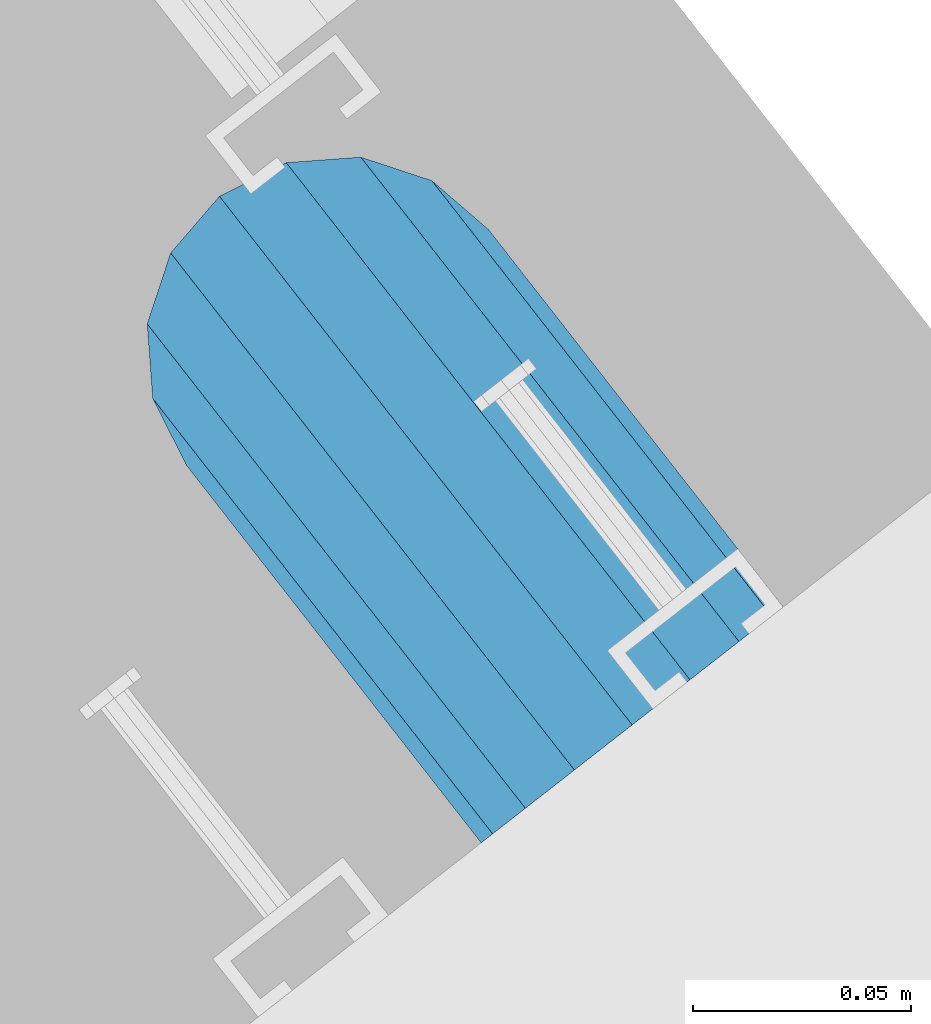
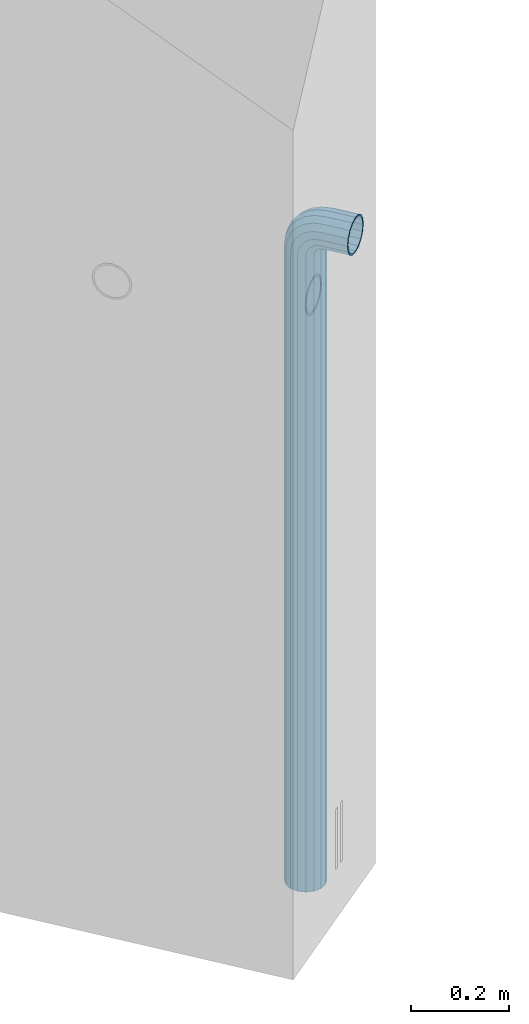
# One storey, part 6 of 42: 1 beam, 2 elements without a shape of their own.
"""IFC2X3 building model written with IfcOpenShell, lengths in millimetres."""

from ifc_helpers import new_model, si_unit, frame, origin_with_axes, place, context, subcontext, project, spatial, faceted_brep, material, type_object, element, aggregate, save


model = new_model("IFC2X3")

# Units and contexts
model_context = context("Model", 3, precision=1e-05, world=origin_with_axes())
body_context = subcontext(model_context, "Body", "Model", "MODEL_VIEW")
ifc_project = project(units=[si_unit("LENGTHUNIT", "METRE", prefix="MILLI"), si_unit("AREAUNIT", "SQUARE_METRE"), si_unit("VOLUMEUNIT", "CUBIC_METRE"), si_unit("MASSUNIT", "GRAM", prefix="KILO"), si_unit("TIMEUNIT", "SECOND"), si_unit("PLANEANGLEUNIT", "RADIAN"), si_unit("SOLIDANGLEUNIT", "STERADIAN"), si_unit("THERMODYNAMICTEMPERATUREUNIT", "DEGREE_CELSIUS"), si_unit("LUMINOUSINTENSITYUNIT", "LUMEN")], contexts=[model_context])

# Site, building, storey
site_placement = place(None, frame((171687.4, 84828.52, 14700.0), z_axis=(0.0, 0.0, 1.0), x_axis=(1.0, 0.0, 0.0)))
site = spatial("IfcSite", under=ifc_project, at=site_placement, CompositionType="ELEMENT")
building_placement = place(site_placement, origin_with_axes())
building = spatial("IfcBuilding", under=site, at=building_placement, Name="Undefined", CompositionType="ELEMENT")
storey_placement = place(building_placement, origin_with_axes())
storey = spatial("IfcBuildingStorey", under=building, at=storey_placement, Name="Undefined", CompositionType="ELEMENT", Elevation=0.0)

# Assemblies, beam
assembly_1_placement = place(storey_placement, origin_with_axes())
assembly_1 = element("IfcElementAssembly", 1, at=assembly_1_placement, inside=storey, AssemblyPlace="NOTDEFINED", PredefinedType="REINFORCEMENT_UNIT")
assembly_2_placement = place(assembly_1_placement, origin_with_axes())
assembly_2 = element("IfcElementAssembly", 2, at=assembly_2_placement, AssemblyPlace="NOTDEFINED", PredefinedType="RIGID_FRAME")
aggregate(assembly_1, [assembly_2])
ifc_material = material(Name="STEEL/NEG_BETON")
beam_type = type_object("IfcBeamType", PredefinedType="NOTDEFINED")
beam_placement = place(assembly_2_placement, frame((18365.8936635989, 265191.472412349, -1290.0), z_axis=(0.615386370178831, -0.788225611990706, 0.0), x_axis=(0.0, 0.0, 1.0)))
beam = element("IfcBeam", 3, at=beam_placement, type_object=beam_type, material=ifc_material, context=body_context, shape_type="Brep", body=[
    faceted_brep([(0.0, -43.999999753345, 2.88331648334861e-07), (0.0, -40.6506991838105, -16.8380707357428), (1590.0, -40.6506991838105, -16.8380707357428), (1589.99999999999, -43.999999753345, 2.88331648334861e-07), (0.0, -31.1126981254783, -31.1126980838017), (1590.0, -31.1126981254783, -31.1126980838017), (0.0, -16.8380707773322, -40.6506991419883), (1590.0, -16.8380707773322, -40.6506991419883), (0.0, 2.46742274612188e-07, -43.9999997114064), (1590.0, 2.46742274612188e-07, -43.9999997114064), (0.0, 16.8380712707876, -40.6506991418137), (1590.0, 16.8380712707876, -40.6506991418137), (0.0, 31.1126986189047, -31.1126980834524), (1590.0, 31.1126986189047, -31.1126980834524), (0.0, 40.6506996771204, -16.8380707352771), (1590.0, 40.6506996771204, -16.8380707352771), (0.0, 44.0000002465677, 2.88768205791712e-07), (1590.0, 44.0000002465677, 2.88768205791712e-07), (0.0, 40.6506996770622, 16.8380713128427), (1590.0, 40.6506996770622, 16.8380713128427), (0.0, 31.1126986187301, 31.1126986609306), (1590.0, 31.1126986187301, 31.1126986609306), (0.0, 16.8380712705839, 40.6506997191464), (1590.0, 16.8380712705839, 40.6506997191464), (0.0, 2.46509443968534e-07, 44.0000002885354), (1590.0, 2.46509443968534e-07, 44.0000002885354), (0.0, -16.8380707775359, 40.6506997189426), (1590.0, -16.8380707775359, 40.6506997189426), (0.0, -31.1126981256821, 31.1126986605814), (1590.0, -31.1126981256821, 31.1126986605814), (0.0, -40.6506991838978, 16.838071312377), (1590.0, -40.6506991838978, 16.838071312377), (4.47878846898675e-07, -40.0000000634464, 0.0), (4.47878846898675e-07, -36.9551813638827, 15.3073372946019), (1590.0, -36.9551810538396, 15.3073375829845), (1589.99999999999, -39.999999753345, 2.88360752165318e-07), (4.47937054559588e-07, -28.2842713108694, 28.284271247463), (1590.0, -28.2842710008845, 28.2842715359002), (4.4800981413573e-07, -15.3073373580119, 36.9551813004509), (1590.0, -15.3073370480561, 36.9551815889135), (4.48068021796644e-07, -6.34463503956795e-08, 40.0), (1590.0, 2.46538547798991e-07, 40.0000002885645), (4.48140781372786e-07, 15.3073372311774, 36.9551813004509), (1590.0, 15.3073375411332, 36.9551815890882), (4.48213540948927e-07, 28.2842711840058, 28.284271247463), (1590.0, 28.2842714939907, 28.2842715361621), (4.48271748609841e-07, 36.95518123699, 15.3073372946019), (1590.0, 36.9551815469749, 15.3073375833046), (4.48286300525069e-07, 39.9999999365536, 0.0), (1590.0, 40.0000002465677, 2.88768205791712e-07), (4.48271748609841e-07, 36.95518123699, -15.3073372946019), (1590.0, 36.9551815470913, -15.3073370058555), (4.48213540948927e-07, 28.2842711840058, -28.284271247463), (1590.0, 28.2842714941071, -28.2842709587712), (4.48140781372786e-07, 15.3073372311774, -36.9551813004509), (1590.0, 15.3073375413369, -36.9551810117846), (4.48068021796644e-07, -6.34463503956795e-08, -40.0), (1590.0, 2.46742274612188e-07, -39.9999997114064), (4.4800981413573e-07, -15.3073373580119, -36.9551813004509), (1590.0, -15.3073370479106, -36.9551810119592), (4.47937054559588e-07, -28.2842713108694, -28.284271247463), (1590.0, -28.284271000739, -28.2842709590332), (4.47878846898675e-07, -36.9551813638827, -15.3073372946019), (1590.0, -36.9551810537523, -15.3073370062048), (1602.94095225512, -43.9999997540726, 1.70370897403336), (1598.5829387913, -40.6506991846254, 17.9680366410757), (1594.88839337186, -31.1126981263515, 31.7562678573595), (1592.41977704577, -16.8380707782635, 40.9692694107944), (1591.55291427061, 2.45810952037573e-07, 44.2044453310082), (1592.41977704577, 16.8380712698563, 40.969269410969), (1594.88839337186, 31.1126986180025, 31.7562678576505), (1598.5829387913, 40.6506996763346, 17.9680366415123), (1602.94095225512, 44.0000002458692, 1.70370897452813), (1607.29896571893, 40.6506996763928, -14.5606186925434), (1610.99351113838, 31.112698618148, -28.3488499088271), (1613.46212746447, 16.83807127006, -37.561851462262), (1614.32899023963, 2.4601467885077e-07, -40.7970273824176), (1613.46212746447, -16.8380707780307, -37.5618514623784), (1610.99351113838, -31.1126981262059, -28.348849909089), (1607.29896571893, -40.650699184509, -14.5606186929217), (1613.29371405922, 2.45985575020313e-07, -36.9333240772539), (1612.50565699089, 15.3073375405802, -33.9922550588963), (1610.26146033081, 28.2842714934086, -25.6167991012626), (1606.90278267677, 36.9551815463637, -13.0820434500929), (1602.94095225512, 40.0000002458692, 1.70370897449902), (1598.97912183347, 36.9551815463055, 16.4894613990327), (1595.62044417943, 28.2842714932631, 29.024217050086), (1593.37624751934, 15.3073375403765, 37.3996730076324), (1592.58819045102, 2.45781848207116e-07, 40.3407420258154), (1593.37624751934, -15.3073370488128, 37.3996730074577), (1595.62044417943, -28.2842710016412, 29.0242170498241), (1598.97912183347, -36.9551810545672, 16.4894613986544), (1602.94095225512, -39.9999997540726, 1.70370897406247), (1606.90278267677, -36.955181054509, -13.0820434504712), (1610.26146033081, -28.2842710014374, -25.6167991015245), (1612.50565699089, -15.307337048609, -33.9922550590418), (1630.55634918609, 31.112698618148, -20.2456570709182), (1635.32534971524, 16.8380712700309, -28.5058082887845), (1623.41903551202, 40.6506996764219, -7.883467157837), (1614.99999999999, 44.0000002458692, 6.69873009974253), (1606.58096448796, 40.6506996763346, 21.2809273572639), (1599.44365081389, 31.1126986180025, 33.6431172702578), (1594.67465028474, 16.8380712698563, 41.9032684879785), (1592.99999999999, 2.45752744376659e-07, 44.8038478659873), (1594.67465028474, -16.8380707782635, 41.9032684878039), (1599.44365081389, -31.1126981263515, 33.6431172699668), (1606.58096448796, -40.6506991846254, 21.2809273568855), (1614.99999999999, -43.9999997540726, 6.69873009927687), (1623.41903551202, -40.6506991845672, -7.88346715827356), (1630.55634918609, -31.1126981262059, -20.2456570712384), (1635.32534971524, -16.8380707780598, -28.5058082889591), (1636.99999999999, 2.45956471189857e-07, -31.4063876669679), (1633.47759065022, -15.3073370486381, -25.3053957082157), (1634.99999999999, 2.45985575020313e-07, -27.9422860518389), (1629.14213562372, -28.2842710014665, -17.7961673284299), (1622.65366864729, -36.9551810545381, -6.55781286209822), (1614.99999999999, -39.9999997541017, 6.69873009933508), (1607.34633135269, -36.9551810545381, 19.9552730607684), (1600.85786437626, -28.2842710016121, 31.1936275271582), (1596.52240934976, -15.3073370487837, 38.7028559070604), (1594.99999999999, 2.45810952037573e-07, 41.3397462508583), (1596.52240934976, 15.3073375404056, 38.702855907206), (1600.85786437626, 28.2842714932631, 31.1936275275075), (1607.34633135269, 36.9551815462473, 19.9552730610885), (1614.99999999999, 40.0000002458692, 6.69873009974253), (1622.65366864729, 36.9551815463346, -6.55781286169076), (1629.14213562372, 28.2842714933795, -17.7961673281679), (1633.47759065022, 15.3073375405511, -25.305395708041), (1647.35533905931, 31.1126986181189, -7.35533877040143), (1654.09972428659, 16.8380712700018, -14.0997239977587), (1637.26165326252, 40.6506996763928, 2.73834702643217), (1625.35533905931, 44.0000002458401, 14.6446612296568), (1613.4490248561, 40.6506996763346, 26.5509754328523), (1603.35533905931, 31.1126986179734, 36.6446612295404), (1596.61095383203, 16.8380712698563, 43.3890464567812), (1594.24264068711, 2.45810952037573e-07, 45.7573596016155), (1596.61095383203, -16.8380707782344, 43.3890464565775), (1603.35533905931, -31.1126981263806, 36.6446612292202), (1613.4490248561, -40.6506991846254, 26.5509754324157), (1625.35533905931, -43.9999997541017, 14.644661229162), (1637.26165326252, -40.6506991845672, 2.73834702599561), (1647.35533905931, -31.1126981262641, -7.35533877075068), (1654.09972428659, -16.838070778118, -14.0997239979333), (1656.46803743151, 2.45956471189857e-07, -16.4680371427676), (1651.48659835683, -15.3073370486381, -11.4865980681498), (1653.63961030677, 2.45956471189857e-07, -13.6396100180573), (1645.35533905931, -28.2842710015248, -5.35533877072157), (1636.17926106223, -36.955181054509, 3.82073922632844), (1625.35533905931, -39.9999997541017, 14.6446612291911), (1614.53141705639, -36.9551810545672, 25.4685832321702), (1605.35533905931, -28.2842710016121, 34.6446612292784), (1599.22407976179, -15.3073370487837, 40.775920526823), (1597.07106781185, 2.45781848207116e-07, 42.9289324768179), (1599.22407976179, 15.3073375403765, 40.7759205269977), (1605.35533905931, 28.2842714932631, 34.6446612295404), (1614.53141705639, 36.9551815462764, 25.4685832324903), (1625.35533905931, 40.0000002458401, 14.6446612296277), (1636.17926106223, 36.9551815463346, 3.82073922670679), (1645.35533905931, 28.2842714933795, -5.35533877045964), (1651.48659835683, 15.307337540522, -11.4865980680042), (1660.24565735981, 31.1126986180607, 9.44365110280341), (1668.50580857761, 16.8380712699436, 4.67465057360823), (1647.88346744676, 40.6506996763055, 16.5809647768911), (1633.3012701892, 44.000000245811, 25.0000002889719), (1618.71907293164, 40.6506996763055, 33.4190358009655), (1606.35688301859, 31.1126986179734, 40.5563494749367), (1598.09673180079, 16.8380712698563, 45.3253500040737), (1595.19615242269, 2.45781848207116e-07, 47.00000028871), (1598.09673180079, -16.8380707782635, 45.32535000387), (1606.35688301859, -31.1126981263806, 40.5563494746748), (1618.71907293164, -40.6506991846545, 33.419035800558), (1633.3012701892, -43.9999997541308, 25.0000002884772), (1647.88346744676, -40.6506991845963, 16.5809647764836), (1660.24565735981, -31.1126981262933, 9.44365110251238), (1668.50580857761, -16.8380707781762, 4.67465057340451), (1671.40638795571, 2.459273673594e-07, 3.00000028876821), (1665.30539599684, -15.3073370486964, 6.52240963847726), (1667.94228634057, 2.45898263528943e-07, 5.00000028876821), (1657.79616761703, -28.2842710015539, 10.8578646648966), (1646.55781315062, -36.9551810545672, 17.3463316412526), (1633.3012701892, -39.9999997541308, 25.0000002885063), (1620.04472722778, -36.9551810546254, 32.6536689358181), (1608.80637276137, -28.2842710016412, 39.1421359122905), (1601.29714438156, -15.3073370488128, 43.4775909388554), (1598.66025403783, 2.45781848207116e-07, 45.0000002886809), (1601.29714438156, 15.3073375403765, 43.4775909390009), (1608.80637276137, 28.2842714932631, 39.1421359125816), (1620.04472722778, 36.9551815462473, 32.6536689362256), (1633.3012701892, 40.0000002458401, 25.0000002889428), (1646.55781315062, 36.9551815463055, 17.346331641631), (1657.79616761703, 28.2842714933213, 10.8578646651586), (1665.30539599684, 15.3073375404638, 6.52240963859367), (1668.34885019768, 31.1126986180316, 29.0064891505172), (1677.56185175105, 16.8380712698563, 26.5378728243522), (1654.56061898146, 40.6506996763055, 32.7010345700255), (1638.29629131443, 44.0000002457818, 37.0590480338433), (1622.0319636474, 40.6506996763055, 41.4170614976319), (1608.24373243118, 31.1126986179734, 45.1116069169948), (1599.03073087781, 16.8380712698563, 47.5802232430142), (1595.79555495772, 2.45781848207116e-07, 48.4470860181027), (1599.03073087781, -16.8380707782635, 47.5802232428396), (1608.24373243118, -31.1126981263806, 45.1116069167037), (1622.0319636474, -40.6506991846836, 41.4170614971954), (1638.29629131443, -43.9999997541599, 37.0590480333485), (1654.56061898146, -40.6506991846254, 32.701034569589), (1668.34885019768, -31.1126981263515, 29.006489150197), (1677.56185175105, -16.8380707782053, 26.5378728241776), (1680.79702767114, 2.4584005586803e-07, 25.6710100491182), (1673.99225534772, -15.3073370487546, 27.4943432977598), (1676.93332436598, 2.4584005586803e-07, 26.7062862295134), (1665.61679939011, -28.284271001583, 29.7385399577906), (1653.082043739, -36.9551810545963, 33.0972176117939), (1638.29629131443, -39.9999997541599, 37.0590480334067), (1623.51053888986, -36.9551810546545, 41.0208784550487), (1610.97578323875, -28.2842710016412, 44.3795561091392), (1602.60032728114, -15.3073370487837, 46.6237527692865), (1599.65925826287, 2.45810952037573e-07, 47.4118098377076), (1602.60032728114, 15.3073375403474, 46.623752769432), (1610.97578323875, 28.284271493234, 44.3795561094012), (1623.51053888986, 36.9551815462182, 41.0208784554561), (1638.29629131443, 40.0000002457818, 37.0590480338142), (1653.082043739, 36.9551815462473, 33.097217612114), (1665.61679939011, 28.2842714932631, 29.7385399580817), (1673.99225534772, 15.3073375404347, 27.4943432979344), (1671.11269837217, -31.1126981263806, 50.0000002885645), (1656.83807102403, -40.6506991847127, 50.0000002885063), (1680.65069943045, -16.8380707782635, 50.0000002886227), (1683.99999999996, 2.45781848207116e-07, 50.0000002887391), (1680.65069943045, 16.8380712698563, 50.0000002887973), (1671.11269837217, 31.1126986179734, 50.0000002888555), (1656.83807102403, 40.6506996762473, 50.0000002889428), (1639.99999999997, 44.0000002457236, 50.0000002889137), (1623.16192897591, 40.6506996762473, 50.0000002889428), (1608.88730162777, 31.1126986179734, 50.0000002888555), (1599.34930056949, 16.8380712698563, 50.0000002887973), (1595.99999999998, 2.45781848207116e-07, 50.0000002887391), (1599.34930056949, -16.8380707782635, 50.0000002886227), (1608.88730162777, -31.1126981263806, 50.0000002885645), (1623.16192897591, -40.6506991846836, 50.0000002885063), (1640.0, -43.999999754189, 50.0000002885063), (1676.95518130041, -15.3073370488128, 50.0000002886227), (1679.99999999996, 2.45781848207116e-07, 50.0000002887391), (1668.28427124742, -28.2842710016703, 50.0000002885645), (1655.30733729457, -36.9551810546545, 50.0000002885354), (1640.0, -39.999999754189, 50.0000002885063), (1624.69266270537, -36.9551810546545, 50.0000002885354), (1611.71572875252, -28.2842710016703, 50.0000002885645), (1603.04481869953, -15.3073370488128, 50.0000002886227), (1599.99999999998, 2.45781848207116e-07, 50.0000002887391), (1603.04481869953, 15.3073375403765, 50.0000002887973), (1611.71572875252, 28.284271493234, 50.0000002888555), (1624.69266270537, 36.9551815461891, 50.0000002888846), (1639.99999999997, 40.0000002457236, 50.0000002889137), (1655.30733729457, 36.9551815461891, 50.0000002889137), (1668.28427124742, 28.284271493234, 50.0000002888555), (1676.95518130041, 15.3073375403765, 50.0000002887973), (1656.83807102406, -40.6506991848582, 110.000000288477), (1640.0, -43.9999997543346, 110.000000288477), (1671.11269837221, -31.1126981265552, 110.000000288535), (1680.6506994305, -16.838070778409, 110.000000288594), (1684.0, 2.45607225224376e-07, 110.00000028871), (1680.6506994305, 16.8380712696817, 110.000000288768), (1671.11269837221, 31.1126986177987, 110.000000288826), (1656.83807102406, 40.6506996761018, 110.000000288914), (1640.0, 44.0000002455781, 110.000000288914), (1623.16192897594, 40.6506996761018, 110.000000288914), (1608.88730162779, 31.1126986177987, 110.000000288826), (1599.3493005695, 16.8380712696817, 110.000000288768), (1596.0, 2.45607225224376e-07, 110.00000028871), (1599.3493005695, -16.838070778409, 110.000000288594), (1608.88730162779, -31.1126981265552, 110.000000288535), (1623.16192897594, -40.6506991848582, 110.000000288477), (1624.6926627054, -36.9551810548001, 110.000000288535), (1640.0, -39.9999997543346, 110.000000288477), (1611.71572875254, -28.2842710018158, 110.000000288535), (1603.04481869955, -15.3073370489583, 110.000000288594), (1600.0, 2.45607225224376e-07, 110.00000028871), (1603.04481869955, 15.3073375402309, 110.000000288768), (1611.71572875254, 28.2842714930885, 110.000000288856), (1624.6926627054, 36.9551815460436, 110.000000288856), (1640.0, 40.0000002455781, 110.000000288885), (1655.3073372946, 36.9551815460436, 110.000000288856), (1668.28427124746, 28.2842714930885, 110.000000288856), (1676.95518130045, 15.3073375402309, 110.000000288768), (1680.0, 2.45607225224376e-07, 110.00000028871), (1676.95518130045, -15.3073370489583, 110.000000288594), (1668.28427124746, -28.2842710018158, 110.000000288535), (1655.3073372946, -36.9551810548001, 110.000000288535)], [[[0, 1, 2, 3]], [[1, 4, 5, 2]], [[4, 6, 7, 5]], [[6, 8, 9, 7]], [[8, 10, 11, 9]], [[10, 12, 13, 11]], [[12, 14, 15, 13]], [[14, 16, 17, 15]], [[16, 18, 19, 17]], [[18, 20, 21, 19]], [[20, 22, 23, 21]], [[22, 24, 25, 23]], [[24, 26, 27, 25]], [[26, 28, 29, 27]], [[28, 30, 31, 29]], [[30, 0, 3, 31]], [[32, 33, 34, 35]], [[33, 36, 37, 34]], [[36, 38, 39, 37]], [[38, 40, 41, 39]], [[40, 42, 43, 41]], [[42, 44, 45, 43]], [[44, 46, 47, 45]], [[46, 48, 49, 47]], [[48, 50, 51, 49]], [[50, 52, 53, 51]], [[52, 54, 55, 53]], [[54, 56, 57, 55]], [[56, 58, 59, 57]], [[58, 60, 61, 59]], [[60, 62, 63, 61]], [[62, 32, 35, 63]], [[30, 28, 26, 24, 22, 20, 18, 16, 14, 12, 10, 8, 6, 4, 1, 0], [62, 60, 58, 56, 54, 52, 50, 48, 46, 44, 42, 40, 38, 36, 33, 32]], [[31, 3, 64, 65]], [[29, 31, 65, 66]], [[27, 29, 66, 67]], [[25, 27, 67, 68]], [[23, 25, 68, 69]], [[21, 23, 69, 70]], [[19, 21, 70, 71]], [[17, 19, 71, 72]], [[15, 17, 72, 73]], [[13, 15, 73, 74]], [[11, 13, 74, 75]], [[9, 11, 75, 76]], [[7, 9, 76, 77]], [[5, 7, 77, 78]], [[2, 5, 78, 79]], [[3, 2, 79, 64]], [[55, 57, 80, 81]], [[53, 55, 81, 82]], [[51, 53, 82, 83]], [[49, 51, 83, 84]], [[47, 49, 84, 85]], [[45, 47, 85, 86]], [[43, 45, 86, 87]], [[41, 43, 87, 88]], [[39, 41, 88, 89]], [[37, 39, 89, 90]], [[34, 37, 90, 91]], [[35, 34, 91, 92]], [[63, 35, 92, 93]], [[61, 63, 93, 94]], [[59, 61, 94, 95]], [[57, 59, 95, 80]], [[74, 96, 97, 75]], [[73, 98, 96, 74]], [[72, 99, 98, 73]], [[71, 100, 99, 72]], [[70, 101, 100, 71]], [[69, 102, 101, 70]], [[68, 103, 102, 69]], [[67, 104, 103, 68]], [[66, 105, 104, 67]], [[65, 106, 105, 66]], [[64, 107, 106, 65]], [[79, 108, 107, 64]], [[78, 109, 108, 79]], [[77, 110, 109, 78]], [[76, 111, 110, 77]], [[75, 97, 111, 76]], [[95, 112, 113, 80]], [[94, 114, 112, 95]], [[93, 115, 114, 94]], [[92, 116, 115, 93]], [[91, 117, 116, 92]], [[90, 118, 117, 91]], [[89, 119, 118, 90]], [[88, 120, 119, 89]], [[87, 121, 120, 88]], [[86, 122, 121, 87]], [[85, 123, 122, 86]], [[84, 124, 123, 85]], [[83, 125, 124, 84]], [[82, 126, 125, 83]], [[81, 127, 126, 82]], [[80, 113, 127, 81]], [[96, 128, 129, 97]], [[98, 130, 128, 96]], [[99, 131, 130, 98]], [[100, 132, 131, 99]], [[101, 133, 132, 100]], [[102, 134, 133, 101]], [[103, 135, 134, 102]], [[104, 136, 135, 103]], [[105, 137, 136, 104]], [[106, 138, 137, 105]], [[107, 139, 138, 106]], [[108, 140, 139, 107]], [[109, 141, 140, 108]], [[110, 142, 141, 109]], [[111, 143, 142, 110]], [[97, 129, 143, 111]], [[112, 144, 145, 113]], [[114, 146, 144, 112]], [[115, 147, 146, 114]], [[116, 148, 147, 115]], [[117, 149, 148, 116]], [[118, 150, 149, 117]], [[119, 151, 150, 118]], [[120, 152, 151, 119]], [[121, 153, 152, 120]], [[122, 154, 153, 121]], [[123, 155, 154, 122]], [[124, 156, 155, 123]], [[125, 157, 156, 124]], [[126, 158, 157, 125]], [[127, 159, 158, 126]], [[113, 145, 159, 127]], [[128, 160, 161, 129]], [[130, 162, 160, 128]], [[131, 163, 162, 130]], [[132, 164, 163, 131]], [[133, 165, 164, 132]], [[134, 166, 165, 133]], [[135, 167, 166, 134]], [[136, 168, 167, 135]], [[137, 169, 168, 136]], [[138, 170, 169, 137]], [[139, 171, 170, 138]], [[140, 172, 171, 139]], [[141, 173, 172, 140]], [[142, 174, 173, 141]], [[143, 175, 174, 142]], [[129, 161, 175, 143]], [[144, 176, 177, 145]], [[146, 178, 176, 144]], [[147, 179, 178, 146]], [[148, 180, 179, 147]], [[149, 181, 180, 148]], [[150, 182, 181, 149]], [[151, 183, 182, 150]], [[152, 184, 183, 151]], [[153, 185, 184, 152]], [[154, 186, 185, 153]], [[155, 187, 186, 154]], [[156, 188, 187, 155]], [[157, 189, 188, 156]], [[158, 190, 189, 157]], [[159, 191, 190, 158]], [[145, 177, 191, 159]], [[160, 192, 193, 161]], [[162, 194, 192, 160]], [[163, 195, 194, 162]], [[164, 196, 195, 163]], [[165, 197, 196, 164]], [[166, 198, 197, 165]], [[167, 199, 198, 166]], [[168, 200, 199, 167]], [[169, 201, 200, 168]], [[170, 202, 201, 169]], [[171, 203, 202, 170]], [[172, 204, 203, 171]], [[173, 205, 204, 172]], [[174, 206, 205, 173]], [[175, 207, 206, 174]], [[161, 193, 207, 175]], [[176, 208, 209, 177]], [[178, 210, 208, 176]], [[179, 211, 210, 178]], [[180, 212, 211, 179]], [[181, 213, 212, 180]], [[182, 214, 213, 181]], [[183, 215, 214, 182]], [[184, 216, 215, 183]], [[185, 217, 216, 184]], [[186, 218, 217, 185]], [[187, 219, 218, 186]], [[188, 220, 219, 187]], [[189, 221, 220, 188]], [[190, 222, 221, 189]], [[191, 223, 222, 190]], [[177, 209, 223, 191]], [[205, 224, 225, 204]], [[206, 226, 224, 205]], [[207, 227, 226, 206]], [[193, 228, 227, 207]], [[192, 229, 228, 193]], [[194, 230, 229, 192]], [[195, 231, 230, 194]], [[196, 232, 231, 195]], [[197, 233, 232, 196]], [[198, 234, 233, 197]], [[199, 235, 234, 198]], [[200, 236, 235, 199]], [[201, 237, 236, 200]], [[202, 238, 237, 201]], [[203, 239, 238, 202]], [[204, 225, 239, 203]], [[208, 240, 241, 209]], [[210, 242, 240, 208]], [[211, 243, 242, 210]], [[212, 244, 243, 211]], [[213, 245, 244, 212]], [[214, 246, 245, 213]], [[215, 247, 246, 214]], [[216, 248, 247, 215]], [[217, 249, 248, 216]], [[218, 250, 249, 217]], [[219, 251, 250, 218]], [[220, 252, 251, 219]], [[221, 253, 252, 220]], [[222, 254, 253, 221]], [[223, 255, 254, 222]], [[209, 241, 255, 223]], [[239, 225, 256, 257]], [[225, 224, 258, 256]], [[224, 226, 259, 258]], [[226, 227, 260, 259]], [[227, 228, 261, 260]], [[228, 229, 262, 261]], [[229, 230, 263, 262]], [[230, 231, 264, 263]], [[231, 232, 265, 264]], [[232, 233, 266, 265]], [[233, 234, 267, 266]], [[234, 235, 268, 267]], [[235, 236, 269, 268]], [[236, 237, 270, 269]], [[237, 238, 271, 270]], [[238, 239, 257, 271]], [[244, 245, 272, 273]], [[245, 246, 274, 272]], [[246, 247, 275, 274]], [[247, 248, 276, 275]], [[248, 249, 277, 276]], [[249, 250, 278, 277]], [[250, 251, 279, 278]], [[251, 252, 280, 279]], [[252, 253, 281, 280]], [[253, 254, 282, 281]], [[254, 255, 283, 282]], [[255, 241, 284, 283]], [[241, 240, 285, 284]], [[240, 242, 286, 285]], [[242, 243, 287, 286]], [[243, 244, 273, 287]], [[258, 259, 260, 261, 262, 263, 264, 265, 266, 267, 268, 269, 270, 271, 257, 256], [274, 275, 276, 277, 278, 279, 280, 281, 282, 283, 284, 285, 286, 287, 273, 272]]]),
])
aggregate(assembly_2, [beam])

save(model, "model.ifc")
